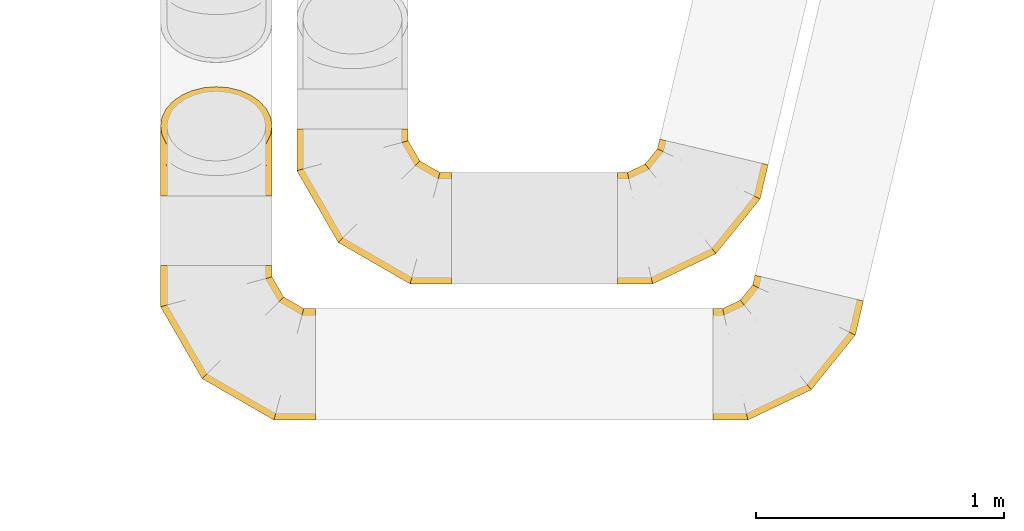
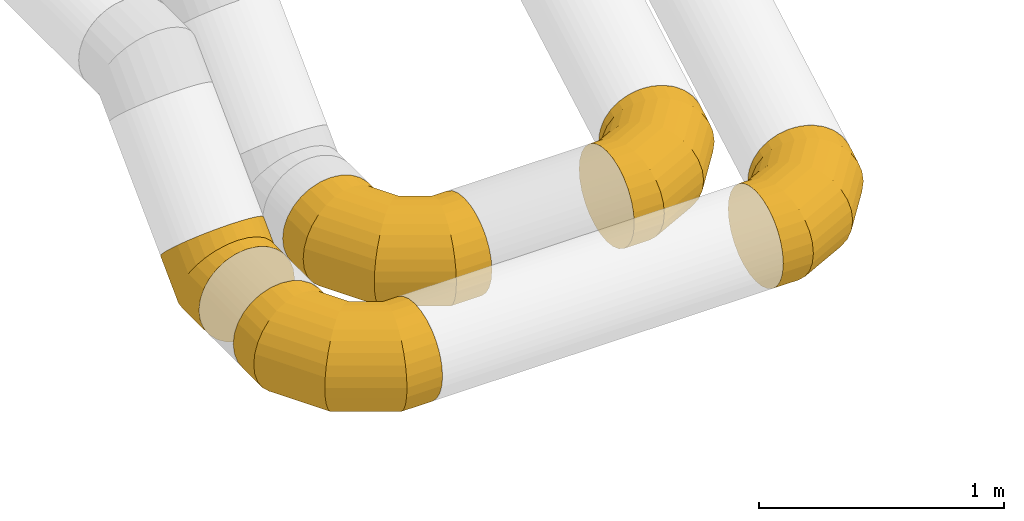
# One storey, part 14 of 97: 5 coverings.
"""IFC2X3 building model written with IfcOpenShell, lengths in millimetres."""

from ifc_helpers import new_model, entity, si_unit, converted_unit, derived_unit, direction, frame, origin, place, context, subcontext, project, spatial, faceted_brep, element, save


model = new_model("IFC2X3")

# Units and contexts
model_context = context("Model", 3, precision=0.01, world=origin(), true_north=direction((6.12303176911189e-17, 1.0)))
body_context = subcontext(model_context, "Body", "Model", "MODEL_VIEW")
ifc_project = project(units=[si_unit("LENGTHUNIT", "METRE", prefix="MILLI"), si_unit("AREAUNIT", "SQUARE_METRE"), si_unit("VOLUMEUNIT", "CUBIC_METRE"), converted_unit("PLANEANGLEUNIT", "DEGREE", entity("IfcRatioMeasure", 0.0174532925199433), si_unit("PLANEANGLEUNIT", "RADIAN"), dimensions=[0, 0, 0, 0, 0, 0, 0]), si_unit("MASSUNIT", "GRAM", prefix="KILO"), derived_unit("MASSDENSITYUNIT", [(si_unit("MASSUNIT", "GRAM", prefix="KILO"), 1), (si_unit("LENGTHUNIT", "METRE"), -3)]), derived_unit("MOMENTOFINERTIAUNIT", [(si_unit("LENGTHUNIT", "METRE"), 4)]), si_unit("TIMEUNIT", "SECOND"), si_unit("FREQUENCYUNIT", "HERTZ"), si_unit("THERMODYNAMICTEMPERATUREUNIT", "DEGREE_CELSIUS"), derived_unit("THERMALTRANSMITTANCEUNIT", [(si_unit("MASSUNIT", "GRAM", prefix="KILO"), 1), (si_unit("THERMODYNAMICTEMPERATUREUNIT", "KELVIN"), -1), (si_unit("TIMEUNIT", "SECOND"), -3)]), derived_unit("VOLUMETRICFLOWRATEUNIT", [(si_unit("LENGTHUNIT", "METRE"), 3), (si_unit("TIMEUNIT", "SECOND"), -1)]), derived_unit("MASSFLOWRATEUNIT", [(si_unit("MASSUNIT", "GRAM", prefix="KILO"), 1), (si_unit("TIMEUNIT", "SECOND"), -1)]), derived_unit("ROTATIONALFREQUENCYUNIT", [(si_unit("TIMEUNIT", "SECOND"), -1)]), si_unit("ELECTRICCURRENTUNIT", "AMPERE"), si_unit("ELECTRICVOLTAGEUNIT", "VOLT"), si_unit("POWERUNIT", "WATT"), si_unit("FORCEUNIT", "NEWTON", prefix="KILO"), si_unit("ILLUMINANCEUNIT", "LUX"), si_unit("LUMINOUSFLUXUNIT", "LUMEN"), si_unit("LUMINOUSINTENSITYUNIT", "CANDELA"), derived_unit("USERDEFINED", [(si_unit("MASSUNIT", "GRAM", prefix="KILO"), -1), (si_unit("LENGTHUNIT", "METRE"), -2), (si_unit("TIMEUNIT", "SECOND"), 3), (si_unit("LUMINOUSFLUXUNIT", "LUMEN"), 1)]), derived_unit("LINEARVELOCITYUNIT", [(si_unit("LENGTHUNIT", "METRE"), 1), (si_unit("TIMEUNIT", "SECOND"), -1)]), si_unit("PRESSUREUNIT", "PASCAL"), derived_unit("USERDEFINED", [(si_unit("LENGTHUNIT", "METRE"), -2), (si_unit("MASSUNIT", "GRAM", prefix="KILO"), 1), (si_unit("TIMEUNIT", "SECOND"), -2)]), derived_unit("LINEARFORCEUNIT", [(si_unit("MASSUNIT", "GRAM", prefix="KILO"), 1), (si_unit("LENGTHUNIT", "METRE"), 1), (si_unit("TIMEUNIT", "SECOND"), -2), (si_unit("LENGTHUNIT", "METRE"), -1)]), derived_unit("PLANARFORCEUNIT", [(si_unit("MASSUNIT", "GRAM", prefix="KILO"), 1), (si_unit("LENGTHUNIT", "METRE"), 1), (si_unit("TIMEUNIT", "SECOND"), -2), (si_unit("LENGTHUNIT", "METRE"), -2)])], contexts=[model_context])

# Site, building, storey
site_placement = place(None, origin())
site = spatial("IfcSite", under=ifc_project, at=site_placement, CompositionType="ELEMENT")
building_placement = place(site_placement, origin())
building = spatial("IfcBuilding", under=site, at=building_placement, CompositionType="ELEMENT")
storey_placement = place(building_placement, frame((0.0, 0.0, -4900.0)))
storey = spatial("IfcBuildingStorey", under=building, at=storey_placement, CompositionType="ELEMENT", Elevation=-4900.0)

# Coverings
covering_1_placement = place(storey_placement, frame((53084.14, 1571.63, 2723.4)))
element("IfcCovering", 1, at=covering_1_placement, inside=storey, PredefinedType="INSULATION", context=body_context, shape_type="Brep", body=[
    faceted_brep([(175.78, 584.96, 276.66), (191.97, 581.13, 324.22), (218.06, 574.95, 366.88), (252.72, 566.74, 402.51), (294.24, 556.91, 429.31), (340.51, 545.95, 445.95), (389.23, 534.41, 451.6), (437.95, 522.87, 445.95), (484.23, 511.91, 429.31), (525.74, 502.08, 402.51), (560.41, 493.87, 366.88), (586.49, 487.69, 324.22), (602.69, 483.85, 276.66), (608.18, 482.55, 226.6), (602.69, 483.85, 176.53), (586.49, 487.69, 128.97), (560.41, 493.87, 86.31), (525.74, 502.08, 50.68), (484.23, 511.91, 23.88), (437.95, 522.87, 7.24), (389.23, 534.41, 1.6), (340.51, 545.95, 7.24), (294.24, 556.91, 23.88), (252.72, 566.74, 50.68), (218.06, 574.95, 86.31), (191.97, 581.13, 128.97), (175.78, 584.96, 176.53), (170.29, 586.26, 226.6), (0.0, 50.68, 86.31), (0.0, 23.88, 128.97), (0.0, 7.24, 176.53), (0.0, 1.6, 226.6), (0.0, 7.24, 276.66), (0.0, 23.88, 324.22), (0.0, 50.68, 366.88), (0.0, 86.31, 402.51), (0.0, 128.97, 429.31), (0.0, 176.53, 445.95), (0.0, 226.6, 451.6), (0.0, 276.66, 445.95), (0.0, 324.22, 429.31), (0.0, 366.88, 402.51), (0.0, 402.51, 366.88), (0.0, 429.31, 324.22), (0.0, 445.95, 276.66), (0.0, 451.6, 226.6), (0.0, 445.95, 176.53), (0.0, 429.31, 128.97), (0.0, 402.51, 86.31), (0.0, 366.88, 50.68), (0.0, 324.22, 23.88), (0.0, 276.66, 7.24), (0.0, 226.6, 1.6), (0.0, 176.53, 7.24), (0.0, 128.97, 23.88), (0.0, 86.31, 50.68), (141.76, 1.6, 226.6), (140.48, 7.24, 276.66), (136.7, 23.88, 324.22), (130.62, 50.68, 366.88), (122.54, 86.31, 402.51), (112.87, 128.97, 429.31), (102.08, 176.53, 445.95), (90.73, 226.6, 451.6), (79.37, 276.66, 445.95), (68.58, 324.22, 429.31), (58.91, 366.88, 402.51), (50.83, 402.51, 366.88), (44.75, 429.31, 324.22), (40.97, 445.95, 276.66), (39.69, 451.6, 226.6), (40.97, 445.95, 176.53), (44.75, 429.31, 128.97), (50.83, 402.51, 86.31), (58.91, 366.88, 50.68), (68.58, 324.22, 23.88), (79.37, 276.66, 7.24), (90.73, 226.6, 1.6), (102.08, 176.53, 7.24), (112.87, 128.97, 23.88), (122.54, 86.31, 50.68), (130.62, 50.68, 86.31), (136.7, 23.88, 128.97), (140.48, 7.24, 176.53), (397.53, 123.91, 226.6), (393.94, 128.45, 276.66), (383.36, 141.83, 324.22), (366.31, 163.39, 366.88), (343.65, 192.05, 402.51), (316.51, 226.36, 429.31), (286.27, 264.61, 445.95), (254.42, 304.88, 451.6), (222.58, 345.15, 445.95), (192.33, 383.4, 429.31), (165.19, 417.71, 402.51), (142.53, 446.36, 366.88), (125.48, 467.92, 324.22), (114.9, 481.31, 276.66), (111.31, 485.84, 226.6), (114.9, 481.31, 176.53), (125.48, 467.92, 128.97), (142.53, 446.36, 86.31), (165.19, 417.71, 50.68), (192.33, 383.4, 23.88), (222.58, 345.15, 7.24), (254.42, 304.88, 1.6), (286.27, 264.61, 7.24), (316.51, 226.36, 23.88), (343.65, 192.05, 50.68), (366.31, 163.39, 86.31), (383.36, 141.83, 128.97), (393.94, 128.45, 176.53), (575.5, 344.61, 226.6), (570.31, 347.16, 276.66), (554.99, 354.66, 324.22), (530.3, 366.76, 366.88), (497.5, 382.83, 402.51), (458.22, 402.08, 429.31), (414.43, 423.54, 445.95), (368.32, 446.13, 451.6), (322.22, 468.71, 445.95), (278.43, 490.17, 429.31), (239.15, 509.42, 402.51), (206.34, 525.49, 366.88), (181.66, 537.59, 324.22), (166.34, 545.09, 276.66), (161.14, 547.64, 226.6), (166.34, 545.09, 176.53), (181.66, 537.59, 128.97), (206.34, 525.49, 86.31), (239.15, 509.42, 50.68), (278.43, 490.17, 23.88), (322.22, 468.71, 7.24), (368.32, 446.13, 1.6), (414.43, 423.54, 7.24), (458.22, 402.08, 23.88), (497.5, 382.83, 50.68), (530.3, 366.76, 86.31), (554.99, 354.66, 128.97), (570.31, 347.16, 176.53)], [[[0, 1, 2, 3, 4, 5, 6, 7, 8, 9, 10, 11, 12, 13, 14, 15, 16, 17, 18, 19, 20, 21, 22, 23, 24, 25, 26, 27]], [[28, 29, 30, 31, 32, 33, 34, 35, 36, 37, 38, 39, 40, 41, 42, 43, 44, 45, 46, 47, 48, 49, 50, 51, 52, 53, 54, 55]], [[31, 56, 57, 32]], [[32, 57, 58, 33]], [[33, 58, 59, 34]], [[59, 60, 35, 34]], [[35, 60, 61, 36]], [[36, 61, 62, 37]], [[37, 62, 63, 38]], [[63, 64, 39, 38]], [[65, 66, 41, 40]], [[64, 65, 40, 39]], [[66, 67, 42, 41]], [[67, 68, 43, 42]], [[69, 70, 45, 44]], [[68, 69, 44, 43]], [[70, 71, 46, 45]], [[72, 73, 48, 47]], [[71, 72, 47, 46]], [[73, 74, 49, 48]], [[74, 75, 50, 49]], [[76, 77, 52, 51]], [[75, 76, 51, 50]], [[53, 52, 77, 78]], [[78, 79, 54, 53]], [[80, 55, 54, 79]], [[80, 81, 28, 55]], [[29, 28, 81, 82]], [[82, 83, 30, 29]], [[56, 31, 30, 83]], [[57, 56, 84, 85]], [[57, 85, 86, 58]], [[59, 58, 86, 87]], [[87, 88, 60, 59]], [[61, 60, 88, 89]], [[62, 61, 89, 90]], [[63, 62, 90, 91]], [[91, 92, 64, 63]], [[93, 94, 66, 65]], [[92, 93, 65, 64]], [[94, 95, 67, 66]], [[95, 96, 68, 67]], [[97, 98, 70, 69]], [[96, 97, 69, 68]], [[98, 99, 71, 70]], [[100, 101, 73, 72]], [[99, 100, 72, 71]], [[101, 102, 74, 73]], [[102, 103, 75, 74]], [[104, 105, 77, 76]], [[103, 104, 76, 75]], [[78, 77, 105, 106]], [[106, 107, 79, 78]], [[108, 80, 79, 107]], [[108, 109, 81, 80]], [[82, 81, 109, 110]], [[110, 111, 83, 82]], [[84, 56, 83, 111]], [[85, 84, 112, 113]], [[85, 113, 114, 86]], [[87, 86, 114, 115]], [[115, 116, 88, 87]], [[89, 88, 116, 117]], [[90, 89, 117, 118]], [[91, 90, 118, 119]], [[119, 120, 92, 91]], [[121, 122, 94, 93]], [[120, 121, 93, 92]], [[122, 123, 95, 94]], [[123, 124, 96, 95]], [[125, 126, 98, 97]], [[124, 125, 97, 96]], [[126, 127, 99, 98]], [[128, 129, 101, 100]], [[127, 128, 100, 99]], [[129, 130, 102, 101]], [[130, 131, 103, 102]], [[132, 133, 105, 104]], [[131, 132, 104, 103]], [[106, 105, 133, 134]], [[134, 135, 107, 106]], [[136, 108, 107, 135]], [[136, 137, 109, 108]], [[110, 109, 137, 138]], [[138, 139, 111, 110]], [[112, 84, 111, 139]], [[113, 112, 13, 12]], [[114, 113, 12, 11]], [[115, 114, 11, 10]], [[10, 9, 116, 115]], [[117, 116, 9, 8]], [[118, 117, 8, 7]], [[119, 118, 7, 6]], [[120, 119, 6, 5]], [[5, 4, 121, 120]], [[3, 122, 121, 4]], [[3, 2, 123, 122]], [[124, 123, 2, 1]], [[125, 124, 1, 0]], [[126, 125, 0, 27]], [[126, 27, 26, 127]], [[26, 25, 128, 127]], [[24, 129, 128, 25]], [[24, 23, 130, 129]], [[130, 23, 22, 131]], [[131, 22, 21, 132]], [[132, 21, 20, 133]], [[133, 20, 19, 134]], [[134, 19, 18, 135]], [[135, 18, 17, 136]], [[17, 16, 137, 136]], [[137, 16, 15, 138]], [[138, 15, 14, 139]], [[139, 14, 13, 112]]]),
])
covering_2_placement = place(storey_placement, frame((51787.5, 1571.63, 2723.4)))
element("IfcCovering", 2, at=covering_2_placement, inside=storey, PredefinedType="INSULATION", context=body_context, shape_type="Brep", body=[
    faceted_brep([(626.6, 226.6, 451.6), (626.6, 176.53, 445.95), (626.6, 128.97, 429.31), (626.6, 86.31, 402.51), (626.6, 50.68, 366.88), (626.6, 23.88, 324.22), (626.6, 7.24, 276.66), (626.6, 1.6, 226.6), (626.6, 7.24, 176.53), (626.6, 23.88, 128.97), (626.6, 50.68, 86.31), (626.6, 86.31, 50.68), (626.6, 128.97, 23.88), (626.6, 176.53, 7.24), (626.6, 226.6, 1.6), (626.6, 276.66, 7.24), (626.6, 324.22, 23.88), (626.6, 366.88, 50.68), (626.6, 402.51, 86.31), (626.6, 429.31, 128.97), (626.6, 445.95, 176.53), (626.6, 451.6, 226.6), (626.6, 445.95, 276.66), (626.6, 429.31, 324.22), (626.6, 402.51, 366.88), (626.6, 366.88, 402.51), (626.6, 324.22, 429.31), (626.6, 276.66, 445.95), (50.68, 626.6, 86.31), (23.88, 626.6, 128.97), (7.24, 626.6, 176.53), (1.6, 626.6, 226.6), (7.24, 626.6, 276.66), (23.88, 626.6, 324.22), (50.68, 626.6, 366.88), (86.31, 626.6, 402.51), (128.97, 626.6, 429.31), (176.53, 626.6, 445.95), (226.6, 626.6, 451.6), (276.66, 626.6, 445.95), (324.22, 626.6, 429.31), (366.88, 626.6, 402.51), (402.51, 626.6, 366.88), (429.31, 626.6, 324.22), (445.95, 626.6, 276.66), (451.6, 626.6, 226.6), (445.95, 626.6, 176.53), (429.31, 626.6, 128.97), (402.51, 626.6, 86.31), (366.88, 626.6, 50.68), (324.22, 626.6, 23.88), (276.66, 626.6, 7.24), (226.6, 626.6, 1.6), (176.53, 626.6, 7.24), (128.97, 626.6, 23.88), (86.31, 626.6, 50.68), (1.6, 459.13, 226.6), (7.24, 460.64, 276.66), (23.88, 465.1, 324.22), (50.68, 472.28, 366.88), (86.31, 481.83, 402.51), (128.97, 493.26, 429.31), (176.53, 506.0, 445.95), (226.6, 519.42, 451.6), (276.66, 532.83, 445.95), (324.22, 545.57, 429.31), (366.88, 557.0, 402.51), (402.51, 566.55, 366.88), (429.31, 573.73, 324.22), (445.95, 578.19, 276.66), (451.6, 579.7, 226.6), (445.95, 578.19, 176.53), (429.31, 573.73, 128.97), (402.51, 566.55, 86.31), (366.88, 557.0, 50.68), (324.22, 545.57, 23.88), (276.66, 532.83, 7.24), (226.6, 519.42, 1.6), (176.53, 506.0, 7.24), (128.97, 493.26, 23.88), (86.31, 481.83, 50.68), (50.68, 472.28, 86.31), (23.88, 465.1, 128.97), (7.24, 460.64, 176.53), (169.06, 169.06, 226.6), (173.19, 173.19, 276.66), (185.38, 185.38, 324.22), (205.0, 205.0, 366.88), (231.08, 231.08, 402.51), (262.31, 262.31, 429.31), (297.12, 297.12, 445.95), (333.77, 333.77, 451.6), (370.43, 370.43, 445.95), (405.24, 405.24, 429.31), (436.47, 436.47, 402.51), (462.55, 462.55, 366.88), (482.17, 482.17, 324.22), (494.36, 494.36, 276.66), (498.49, 498.49, 226.6), (494.36, 494.36, 176.53), (482.17, 482.17, 128.97), (462.55, 462.55, 86.31), (436.47, 436.47, 50.68), (405.24, 405.24, 23.88), (370.43, 370.43, 7.24), (333.77, 333.77, 1.6), (297.12, 297.12, 7.24), (262.31, 262.31, 23.88), (231.08, 231.08, 50.68), (205.0, 205.0, 86.31), (185.38, 185.38, 128.97), (173.19, 173.19, 176.53), (459.13, 1.6, 226.6), (460.64, 7.24, 276.66), (465.1, 23.88, 324.22), (472.28, 50.68, 366.88), (481.83, 86.31, 402.51), (493.26, 128.97, 429.31), (506.0, 176.53, 445.95), (519.42, 226.6, 451.6), (532.83, 276.66, 445.95), (545.57, 324.22, 429.31), (557.0, 366.88, 402.51), (566.55, 402.51, 366.88), (573.73, 429.31, 324.22), (578.19, 445.95, 276.66), (579.7, 451.6, 226.6), (578.19, 445.95, 176.53), (573.73, 429.31, 128.97), (566.55, 402.51, 86.31), (557.0, 366.88, 50.68), (545.57, 324.22, 23.88), (532.83, 276.66, 7.24), (519.42, 226.6, 1.6), (506.0, 176.53, 7.24), (493.26, 128.97, 23.88), (481.83, 86.31, 50.68), (472.28, 50.68, 86.31), (465.1, 23.88, 128.97), (460.64, 7.24, 176.53)], [[[0, 1, 2, 3, 4, 5, 6, 7, 8, 9, 10, 11, 12, 13, 14, 15, 16, 17, 18, 19, 20, 21, 22, 23, 24, 25, 26, 27]], [[28, 29, 30, 31, 32, 33, 34, 35, 36, 37, 38, 39, 40, 41, 42, 43, 44, 45, 46, 47, 48, 49, 50, 51, 52, 53, 54, 55]], [[31, 56, 57, 32]], [[32, 57, 58, 33]], [[33, 58, 59, 34]], [[59, 60, 35, 34]], [[35, 60, 61, 36]], [[36, 61, 62, 37]], [[37, 62, 63, 38]], [[63, 64, 39, 38]], [[65, 66, 41, 40]], [[64, 65, 40, 39]], [[66, 67, 42, 41]], [[67, 68, 43, 42]], [[69, 70, 45, 44]], [[68, 69, 44, 43]], [[70, 71, 46, 45]], [[72, 73, 48, 47]], [[71, 72, 47, 46]], [[73, 74, 49, 48]], [[74, 75, 50, 49]], [[76, 77, 52, 51]], [[75, 76, 51, 50]], [[53, 52, 77, 78]], [[78, 79, 54, 53]], [[80, 55, 54, 79]], [[80, 81, 28, 55]], [[29, 28, 81, 82]], [[82, 83, 30, 29]], [[56, 31, 30, 83]], [[57, 56, 84, 85]], [[57, 85, 86, 58]], [[59, 58, 86, 87]], [[87, 88, 60, 59]], [[61, 60, 88, 89]], [[62, 61, 89, 90]], [[63, 62, 90, 91]], [[91, 92, 64, 63]], [[93, 94, 66, 65]], [[92, 93, 65, 64]], [[94, 95, 67, 66]], [[95, 96, 68, 67]], [[97, 98, 70, 69]], [[96, 97, 69, 68]], [[98, 99, 71, 70]], [[100, 101, 73, 72]], [[99, 100, 72, 71]], [[101, 102, 74, 73]], [[102, 103, 75, 74]], [[104, 105, 77, 76]], [[103, 104, 76, 75]], [[78, 77, 105, 106]], [[106, 107, 79, 78]], [[108, 80, 79, 107]], [[108, 109, 81, 80]], [[82, 81, 109, 110]], [[110, 111, 83, 82]], [[84, 56, 83, 111]], [[85, 84, 112, 113]], [[85, 113, 114, 86]], [[87, 86, 114, 115]], [[115, 116, 88, 87]], [[89, 88, 116, 117]], [[90, 89, 117, 118]], [[91, 90, 118, 119]], [[119, 120, 92, 91]], [[121, 122, 94, 93]], [[120, 121, 93, 92]], [[122, 123, 95, 94]], [[123, 124, 96, 95]], [[125, 126, 98, 97]], [[124, 125, 97, 96]], [[126, 127, 99, 98]], [[128, 129, 101, 100]], [[127, 128, 100, 99]], [[129, 130, 102, 101]], [[130, 131, 103, 102]], [[132, 133, 105, 104]], [[131, 132, 104, 103]], [[106, 105, 133, 134]], [[134, 135, 107, 106]], [[136, 108, 107, 135]], [[136, 137, 109, 108]], [[110, 109, 137, 138]], [[138, 139, 111, 110]], [[112, 84, 111, 139]], [[113, 112, 7, 6]], [[5, 4, 115, 114]], [[114, 113, 6, 5]], [[4, 3, 116, 115]], [[117, 116, 3, 2]], [[118, 117, 2, 1]], [[119, 118, 1, 0]], [[120, 119, 0, 27]], [[26, 25, 122, 121]], [[121, 120, 27, 26]], [[25, 24, 123, 122]], [[124, 123, 24, 23]], [[125, 124, 23, 22]], [[126, 125, 22, 21]], [[21, 20, 127, 126]], [[20, 19, 128, 127]], [[128, 19, 18, 129]], [[18, 17, 130, 129]], [[130, 17, 16, 131]], [[131, 16, 15, 132]], [[132, 15, 14, 133]], [[133, 14, 13, 134]], [[134, 13, 12, 135]], [[135, 12, 11, 136]], [[11, 10, 137, 136]], [[137, 10, 9, 138]], [[138, 9, 8, 139]], [[139, 8, 7, 112]]]),
])
covering_3_placement = place(storey_placement, frame((51237.56, 1927.86, 2723.4)))
element("IfcCovering", 3, at=covering_3_placement, inside=storey, PredefinedType="INSULATION", context=body_context, shape_type="Brep", body=[
    faceted_brep([(176.53, 0.0, 445.95), (128.97, 0.0, 429.31), (86.31, 0.0, 402.51), (50.68, 0.0, 366.88), (23.88, 0.0, 324.22), (7.24, 0.0, 276.66), (1.6, 0.0, 226.6), (7.24, 0.0, 176.53), (23.88, 0.0, 128.97), (50.68, 0.0, 86.31), (86.31, 0.0, 50.68), (128.97, 0.0, 23.88), (176.53, 0.0, 7.24), (226.6, 0.0, 1.6), (276.66, 0.0, 7.24), (324.22, 0.0, 23.88), (366.88, 0.0, 50.68), (402.51, 0.0, 86.31), (429.31, 0.0, 128.97), (445.95, 0.0, 176.53), (451.6, 0.0, 226.6), (445.95, 0.0, 276.66), (429.31, 0.0, 324.22), (402.51, 0.0, 366.88), (366.88, 0.0, 402.51), (324.22, 0.0, 429.31), (276.66, 0.0, 445.95), (226.6, 0.0, 451.6), (366.88, 407.23, 219.36), (324.22, 426.19, 200.41), (276.66, 437.95, 188.64), (226.6, 441.94, 184.65), (176.53, 437.95, 188.64), (128.97, 426.19, 200.41), (86.31, 407.23, 219.36), (50.68, 382.04, 244.56), (23.88, 351.87, 274.72), (7.24, 318.25, 308.35), (1.6, 282.84, 343.75), (7.24, 247.44, 379.16), (23.88, 213.81, 412.78), (50.68, 183.65, 442.95), (86.31, 158.45, 468.14), (128.97, 139.5, 487.1), (176.53, 127.73, 498.86), (226.6, 123.74, 502.85), (276.66, 127.73, 498.86), (324.22, 139.5, 487.1), (366.88, 158.45, 468.14), (402.51, 183.65, 442.95), (429.31, 213.81, 412.78), (445.95, 247.44, 379.16), (451.6, 282.84, 343.75), (445.95, 318.25, 308.35), (429.31, 351.87, 274.72), (402.51, 382.04, 244.56), (226.6, 258.88, 1.6), (176.53, 256.55, 7.24), (128.97, 249.65, 23.88), (86.31, 238.55, 50.68), (50.68, 223.79, 86.31), (23.88, 206.12, 128.97), (7.24, 186.42, 176.53), (1.6, 165.69, 226.6), (7.24, 144.95, 276.66), (23.88, 125.25, 324.22), (50.68, 107.58, 366.88), (86.31, 92.82, 402.51), (128.97, 81.72, 429.31), (176.53, 74.82, 445.95), (226.6, 72.49, 451.6), (276.66, 74.82, 445.95), (324.22, 81.72, 429.31), (366.88, 92.82, 402.51), (402.51, 107.58, 366.88), (429.31, 125.25, 324.22), (445.95, 144.95, 276.66), (451.6, 165.69, 226.6), (445.95, 186.42, 176.53), (429.31, 206.12, 128.97), (402.51, 223.79, 86.31), (366.88, 238.55, 50.68), (324.22, 249.65, 23.88), (276.66, 256.55, 7.24)], [[[0, 1, 2, 3, 4, 5, 6, 7, 8, 9, 10, 11, 12, 13, 14, 15, 16, 17, 18, 19, 20, 21, 22, 23, 24, 25, 26, 27]], [[28, 29, 30, 31, 32, 33, 34, 35, 36, 37, 38, 39, 40, 41, 42, 43, 44, 45, 46, 47, 48, 49, 50, 51, 52, 53, 54, 55]], [[31, 56, 57, 32]], [[32, 57, 58, 33]], [[33, 58, 59, 34]], [[59, 60, 35, 34]], [[35, 60, 61, 36]], [[36, 61, 62, 37]], [[37, 62, 63, 38]], [[63, 64, 39, 38]], [[65, 66, 41, 40]], [[64, 65, 40, 39]], [[66, 67, 42, 41]], [[67, 68, 43, 42]], [[69, 70, 45, 44]], [[68, 69, 44, 43]], [[70, 71, 46, 45]], [[72, 73, 48, 47]], [[71, 72, 47, 46]], [[73, 74, 49, 48]], [[74, 75, 50, 49]], [[76, 77, 52, 51]], [[75, 76, 51, 50]], [[53, 52, 77, 78]], [[78, 79, 54, 53]], [[80, 55, 54, 79]], [[80, 81, 28, 55]], [[29, 28, 81, 82]], [[82, 83, 30, 29]], [[56, 31, 30, 83]], [[13, 12, 57, 56]], [[11, 10, 59, 58]], [[12, 11, 58, 57]], [[10, 9, 60, 59]], [[61, 60, 9, 8]], [[62, 61, 8, 7]], [[63, 62, 7, 6]], [[64, 63, 6, 5]], [[65, 64, 5, 4]], [[66, 65, 4, 3]], [[3, 2, 67, 66]], [[68, 67, 2, 1]], [[69, 68, 1, 0]], [[70, 69, 0, 27]], [[70, 27, 26, 71]], [[71, 26, 25, 72]], [[72, 25, 24, 73]], [[24, 23, 74, 73]], [[74, 23, 22, 75]], [[75, 22, 21, 76]], [[76, 21, 20, 77]], [[77, 20, 19, 78]], [[78, 19, 18, 79]], [[79, 18, 17, 80]], [[17, 16, 81, 80]], [[81, 16, 15, 82]], [[82, 15, 14, 83]], [[83, 14, 13, 56]]]),
])
covering_4_placement = place(storey_placement, frame((51237.56, 1022.13, 2723.4)))
element("IfcCovering", 4, at=covering_4_placement, inside=storey, PredefinedType="INSULATION", context=body_context, shape_type="Brep", body=[
    faceted_brep([(626.6, 226.6, 451.6), (626.6, 176.53, 445.95), (626.6, 128.97, 429.31), (626.6, 86.31, 402.51), (626.6, 50.68, 366.88), (626.6, 23.88, 324.22), (626.6, 7.24, 276.66), (626.6, 1.6, 226.6), (626.6, 7.24, 176.53), (626.6, 23.88, 128.97), (626.6, 50.68, 86.31), (626.6, 86.31, 50.68), (626.6, 128.97, 23.88), (626.6, 176.53, 7.24), (626.6, 226.6, 1.6), (626.6, 276.66, 7.24), (626.6, 324.22, 23.88), (626.6, 366.88, 50.68), (626.6, 402.51, 86.31), (626.6, 429.31, 128.97), (626.6, 445.95, 176.53), (626.6, 451.6, 226.6), (626.6, 445.95, 276.66), (626.6, 429.31, 324.22), (626.6, 402.51, 366.88), (626.6, 366.88, 402.51), (626.6, 324.22, 429.31), (626.6, 276.66, 445.95), (50.68, 626.6, 86.31), (23.88, 626.6, 128.97), (7.24, 626.6, 176.53), (1.6, 626.6, 226.6), (7.24, 626.6, 276.66), (23.88, 626.6, 324.22), (50.68, 626.6, 366.88), (86.31, 626.6, 402.51), (128.97, 626.6, 429.31), (176.53, 626.6, 445.95), (226.6, 626.6, 451.6), (276.66, 626.6, 445.95), (324.22, 626.6, 429.31), (366.88, 626.6, 402.51), (402.51, 626.6, 366.88), (429.31, 626.6, 324.22), (445.95, 626.6, 276.66), (451.6, 626.6, 226.6), (445.95, 626.6, 176.53), (429.31, 626.6, 128.97), (402.51, 626.6, 86.31), (366.88, 626.6, 50.68), (324.22, 626.6, 23.88), (276.66, 626.6, 7.24), (226.6, 626.6, 1.6), (176.53, 626.6, 7.24), (128.97, 626.6, 23.88), (86.31, 626.6, 50.68), (1.6, 459.13, 226.6), (7.24, 460.64, 276.66), (23.88, 465.1, 324.22), (50.68, 472.28, 366.88), (86.31, 481.83, 402.51), (128.97, 493.26, 429.31), (176.53, 506.0, 445.95), (226.6, 519.42, 451.6), (276.66, 532.83, 445.95), (324.22, 545.57, 429.31), (366.88, 557.0, 402.51), (402.51, 566.55, 366.88), (429.31, 573.73, 324.22), (445.95, 578.19, 276.66), (451.6, 579.7, 226.6), (445.95, 578.19, 176.53), (429.31, 573.73, 128.97), (402.51, 566.55, 86.31), (366.88, 557.0, 50.68), (324.22, 545.57, 23.88), (276.66, 532.83, 7.24), (226.6, 519.42, 1.6), (176.53, 506.0, 7.24), (128.97, 493.26, 23.88), (86.31, 481.83, 50.68), (50.68, 472.28, 86.31), (23.88, 465.1, 128.97), (7.24, 460.64, 176.53), (169.06, 169.06, 226.6), (173.19, 173.19, 276.66), (185.38, 185.38, 324.22), (205.0, 205.0, 366.88), (231.08, 231.08, 402.51), (262.31, 262.31, 429.31), (297.12, 297.12, 445.95), (333.77, 333.77, 451.6), (370.43, 370.43, 445.95), (405.24, 405.24, 429.31), (436.47, 436.47, 402.51), (462.55, 462.55, 366.88), (482.17, 482.17, 324.22), (494.36, 494.36, 276.66), (498.49, 498.49, 226.6), (494.36, 494.36, 176.53), (482.17, 482.17, 128.97), (462.55, 462.55, 86.31), (436.47, 436.47, 50.68), (405.24, 405.24, 23.88), (370.43, 370.43, 7.24), (333.77, 333.77, 1.6), (297.12, 297.12, 7.24), (262.31, 262.31, 23.88), (231.08, 231.08, 50.68), (205.0, 205.0, 86.31), (185.38, 185.38, 128.97), (173.19, 173.19, 176.53), (459.13, 1.6, 226.6), (460.64, 7.24, 276.66), (465.1, 23.88, 324.22), (472.28, 50.68, 366.88), (481.83, 86.31, 402.51), (493.26, 128.97, 429.31), (506.0, 176.53, 445.95), (519.42, 226.6, 451.6), (532.83, 276.66, 445.95), (545.57, 324.22, 429.31), (557.0, 366.88, 402.51), (566.55, 402.51, 366.88), (573.73, 429.31, 324.22), (578.19, 445.95, 276.66), (579.7, 451.6, 226.6), (578.19, 445.95, 176.53), (573.73, 429.31, 128.97), (566.55, 402.51, 86.31), (557.0, 366.88, 50.68), (545.57, 324.22, 23.88), (532.83, 276.66, 7.24), (519.42, 226.6, 1.6), (506.0, 176.53, 7.24), (493.26, 128.97, 23.88), (481.83, 86.31, 50.68), (472.28, 50.68, 86.31), (465.1, 23.88, 128.97), (460.64, 7.24, 176.53)], [[[0, 1, 2, 3, 4, 5, 6, 7, 8, 9, 10, 11, 12, 13, 14, 15, 16, 17, 18, 19, 20, 21, 22, 23, 24, 25, 26, 27]], [[28, 29, 30, 31, 32, 33, 34, 35, 36, 37, 38, 39, 40, 41, 42, 43, 44, 45, 46, 47, 48, 49, 50, 51, 52, 53, 54, 55]], [[31, 56, 57, 32]], [[32, 57, 58, 33]], [[33, 58, 59, 34]], [[59, 60, 35, 34]], [[35, 60, 61, 36]], [[36, 61, 62, 37]], [[37, 62, 63, 38]], [[63, 64, 39, 38]], [[65, 66, 41, 40]], [[64, 65, 40, 39]], [[66, 67, 42, 41]], [[67, 68, 43, 42]], [[69, 70, 45, 44]], [[68, 69, 44, 43]], [[70, 71, 46, 45]], [[72, 73, 48, 47]], [[71, 72, 47, 46]], [[73, 74, 49, 48]], [[74, 75, 50, 49]], [[76, 77, 52, 51]], [[75, 76, 51, 50]], [[53, 52, 77, 78]], [[78, 79, 54, 53]], [[80, 55, 54, 79]], [[80, 81, 28, 55]], [[29, 28, 81, 82]], [[82, 83, 30, 29]], [[56, 31, 30, 83]], [[57, 56, 84, 85]], [[57, 85, 86, 58]], [[59, 58, 86, 87]], [[87, 88, 60, 59]], [[61, 60, 88, 89]], [[62, 61, 89, 90]], [[63, 62, 90, 91]], [[91, 92, 64, 63]], [[93, 94, 66, 65]], [[92, 93, 65, 64]], [[94, 95, 67, 66]], [[95, 96, 68, 67]], [[97, 98, 70, 69]], [[96, 97, 69, 68]], [[98, 99, 71, 70]], [[100, 101, 73, 72]], [[99, 100, 72, 71]], [[101, 102, 74, 73]], [[102, 103, 75, 74]], [[104, 105, 77, 76]], [[103, 104, 76, 75]], [[78, 77, 105, 106]], [[106, 107, 79, 78]], [[108, 80, 79, 107]], [[108, 109, 81, 80]], [[82, 81, 109, 110]], [[110, 111, 83, 82]], [[84, 56, 83, 111]], [[85, 84, 112, 113]], [[85, 113, 114, 86]], [[87, 86, 114, 115]], [[115, 116, 88, 87]], [[89, 88, 116, 117]], [[90, 89, 117, 118]], [[91, 90, 118, 119]], [[119, 120, 92, 91]], [[121, 122, 94, 93]], [[120, 121, 93, 92]], [[122, 123, 95, 94]], [[123, 124, 96, 95]], [[125, 126, 98, 97]], [[124, 125, 97, 96]], [[126, 127, 99, 98]], [[128, 129, 101, 100]], [[127, 128, 100, 99]], [[129, 130, 102, 101]], [[130, 131, 103, 102]], [[132, 133, 105, 104]], [[131, 132, 104, 103]], [[106, 105, 133, 134]], [[134, 135, 107, 106]], [[136, 108, 107, 135]], [[136, 137, 109, 108]], [[110, 109, 137, 138]], [[138, 139, 111, 110]], [[112, 84, 111, 139]], [[113, 112, 7, 6]], [[5, 4, 115, 114]], [[114, 113, 6, 5]], [[4, 3, 116, 115]], [[117, 116, 3, 2]], [[118, 117, 2, 1]], [[119, 118, 1, 0]], [[120, 119, 0, 27]], [[26, 25, 122, 121]], [[121, 120, 27, 26]], [[25, 24, 123, 122]], [[124, 123, 24, 23]], [[125, 124, 23, 22]], [[126, 125, 22, 21]], [[21, 20, 127, 126]], [[20, 19, 128, 127]], [[128, 19, 18, 129]], [[18, 17, 130, 129]], [[130, 17, 16, 131]], [[131, 16, 15, 132]], [[132, 15, 14, 133]], [[133, 14, 13, 134]], [[134, 13, 12, 135]], [[135, 12, 11, 136]], [[11, 10, 137, 136]], [[137, 10, 9, 138]], [[138, 9, 8, 139]], [[139, 8, 7, 112]]]),
])
covering_5_placement = place(storey_placement, frame((53468.75, 1022.13, 2723.4)))
element("IfcCovering", 5, at=covering_5_placement, inside=storey, PredefinedType="INSULATION", context=body_context, shape_type="Brep", body=[
    faceted_brep([(294.24, 556.91, 429.31), (340.51, 545.95, 445.95), (389.23, 534.41, 451.6), (437.95, 522.87, 445.95), (484.23, 511.91, 429.31), (525.74, 502.08, 402.51), (560.41, 493.87, 366.88), (586.49, 487.69, 324.22), (602.69, 483.85, 276.66), (608.18, 482.55, 226.6), (602.69, 483.85, 176.53), (586.49, 487.69, 128.97), (560.41, 493.87, 86.31), (525.74, 502.08, 50.68), (484.23, 511.91, 23.88), (437.95, 522.87, 7.24), (389.23, 534.41, 1.6), (340.51, 545.95, 7.24), (294.24, 556.91, 23.88), (252.72, 566.74, 50.68), (218.06, 574.95, 86.31), (191.97, 581.13, 128.97), (175.78, 584.96, 176.53), (170.29, 586.26, 226.6), (175.78, 584.96, 276.66), (191.97, 581.13, 324.22), (218.06, 574.95, 366.88), (252.72, 566.74, 402.51), (0.0, 50.68, 86.31), (0.0, 23.88, 128.97), (0.0, 7.24, 176.53), (0.0, 1.6, 226.6), (0.0, 7.24, 276.66), (0.0, 23.88, 324.22), (0.0, 50.68, 366.88), (0.0, 86.31, 402.51), (0.0, 128.97, 429.31), (0.0, 176.53, 445.95), (0.0, 226.6, 451.6), (0.0, 276.66, 445.95), (0.0, 324.22, 429.31), (0.0, 366.88, 402.51), (0.0, 402.51, 366.88), (0.0, 429.31, 324.22), (0.0, 445.95, 276.66), (0.0, 451.6, 226.6), (0.0, 445.95, 176.53), (0.0, 429.31, 128.97), (0.0, 402.51, 86.31), (0.0, 366.88, 50.68), (0.0, 324.22, 23.88), (0.0, 276.66, 7.24), (0.0, 226.6, 1.6), (0.0, 176.53, 7.24), (0.0, 128.97, 23.88), (0.0, 86.31, 50.68), (141.76, 1.6, 226.6), (140.48, 7.24, 276.66), (136.7, 23.88, 324.22), (130.62, 50.68, 366.88), (122.54, 86.31, 402.51), (112.87, 128.97, 429.31), (102.08, 176.53, 445.95), (90.73, 226.6, 451.6), (79.37, 276.66, 445.95), (68.58, 324.22, 429.31), (58.91, 366.88, 402.51), (50.83, 402.51, 366.88), (44.75, 429.31, 324.22), (40.97, 445.95, 276.66), (39.69, 451.6, 226.6), (40.97, 445.95, 176.53), (44.75, 429.31, 128.97), (50.83, 402.51, 86.31), (58.91, 366.88, 50.68), (68.58, 324.22, 23.88), (79.37, 276.66, 7.24), (90.73, 226.6, 1.6), (102.08, 176.53, 7.24), (112.87, 128.97, 23.88), (122.54, 86.31, 50.68), (130.62, 50.68, 86.31), (136.7, 23.88, 128.97), (140.48, 7.24, 176.53), (397.53, 123.91, 226.6), (393.94, 128.45, 276.66), (383.36, 141.83, 324.22), (366.31, 163.39, 366.88), (343.65, 192.05, 402.51), (316.51, 226.36, 429.31), (286.27, 264.61, 445.95), (254.42, 304.88, 451.6), (222.58, 345.15, 445.95), (192.33, 383.4, 429.31), (165.19, 417.71, 402.51), (142.53, 446.36, 366.88), (125.48, 467.92, 324.22), (114.9, 481.31, 276.66), (111.31, 485.84, 226.6), (114.9, 481.31, 176.53), (125.48, 467.92, 128.97), (142.53, 446.36, 86.31), (165.19, 417.71, 50.68), (192.33, 383.4, 23.88), (222.58, 345.15, 7.24), (254.42, 304.88, 1.6), (286.27, 264.61, 7.24), (316.51, 226.36, 23.88), (343.65, 192.05, 50.68), (366.31, 163.39, 86.31), (383.36, 141.83, 128.97), (393.94, 128.45, 176.53), (575.5, 344.61, 226.6), (570.31, 347.16, 276.66), (554.99, 354.66, 324.22), (530.3, 366.76, 366.88), (497.5, 382.83, 402.51), (458.22, 402.08, 429.31), (414.43, 423.54, 445.95), (368.32, 446.13, 451.6), (322.22, 468.71, 445.95), (278.43, 490.17, 429.31), (239.15, 509.42, 402.51), (206.34, 525.49, 366.88), (181.66, 537.59, 324.22), (166.34, 545.09, 276.66), (161.14, 547.64, 226.6), (166.34, 545.09, 176.53), (181.66, 537.59, 128.97), (206.34, 525.49, 86.31), (239.15, 509.42, 50.68), (278.43, 490.17, 23.88), (322.22, 468.71, 7.24), (368.32, 446.13, 1.6), (414.43, 423.54, 7.24), (458.22, 402.08, 23.88), (497.5, 382.83, 50.68), (530.3, 366.76, 86.31), (554.99, 354.66, 128.97), (570.31, 347.16, 176.53)], [[[0, 1, 2, 3, 4, 5, 6, 7, 8, 9, 10, 11, 12, 13, 14, 15, 16, 17, 18, 19, 20, 21, 22, 23, 24, 25, 26, 27]], [[28, 29, 30, 31, 32, 33, 34, 35, 36, 37, 38, 39, 40, 41, 42, 43, 44, 45, 46, 47, 48, 49, 50, 51, 52, 53, 54, 55]], [[31, 56, 57, 32]], [[32, 57, 58, 33]], [[33, 58, 59, 34]], [[59, 60, 35, 34]], [[35, 60, 61, 36]], [[36, 61, 62, 37]], [[37, 62, 63, 38]], [[63, 64, 39, 38]], [[65, 66, 41, 40]], [[64, 65, 40, 39]], [[66, 67, 42, 41]], [[67, 68, 43, 42]], [[69, 70, 45, 44]], [[68, 69, 44, 43]], [[70, 71, 46, 45]], [[72, 73, 48, 47]], [[71, 72, 47, 46]], [[73, 74, 49, 48]], [[74, 75, 50, 49]], [[76, 77, 52, 51]], [[75, 76, 51, 50]], [[53, 52, 77, 78]], [[78, 79, 54, 53]], [[80, 55, 54, 79]], [[80, 81, 28, 55]], [[29, 28, 81, 82]], [[82, 83, 30, 29]], [[56, 31, 30, 83]], [[57, 56, 84, 85]], [[57, 85, 86, 58]], [[59, 58, 86, 87]], [[87, 88, 60, 59]], [[61, 60, 88, 89]], [[62, 61, 89, 90]], [[63, 62, 90, 91]], [[91, 92, 64, 63]], [[93, 94, 66, 65]], [[92, 93, 65, 64]], [[94, 95, 67, 66]], [[95, 96, 68, 67]], [[97, 98, 70, 69]], [[96, 97, 69, 68]], [[98, 99, 71, 70]], [[100, 101, 73, 72]], [[99, 100, 72, 71]], [[101, 102, 74, 73]], [[102, 103, 75, 74]], [[104, 105, 77, 76]], [[103, 104, 76, 75]], [[78, 77, 105, 106]], [[106, 107, 79, 78]], [[108, 80, 79, 107]], [[108, 109, 81, 80]], [[82, 81, 109, 110]], [[110, 111, 83, 82]], [[84, 56, 83, 111]], [[85, 84, 112, 113]], [[85, 113, 114, 86]], [[87, 86, 114, 115]], [[115, 116, 88, 87]], [[89, 88, 116, 117]], [[90, 89, 117, 118]], [[91, 90, 118, 119]], [[119, 120, 92, 91]], [[121, 122, 94, 93]], [[120, 121, 93, 92]], [[122, 123, 95, 94]], [[123, 124, 96, 95]], [[125, 126, 98, 97]], [[124, 125, 97, 96]], [[126, 127, 99, 98]], [[128, 129, 101, 100]], [[127, 128, 100, 99]], [[129, 130, 102, 101]], [[130, 131, 103, 102]], [[132, 133, 105, 104]], [[131, 132, 104, 103]], [[106, 105, 133, 134]], [[134, 135, 107, 106]], [[136, 108, 107, 135]], [[136, 137, 109, 108]], [[110, 109, 137, 138]], [[138, 139, 111, 110]], [[112, 84, 111, 139]], [[113, 112, 9, 8]], [[7, 6, 115, 114]], [[114, 113, 8, 7]], [[6, 5, 116, 115]], [[117, 116, 5, 4]], [[118, 117, 4, 3]], [[119, 118, 3, 2]], [[120, 119, 2, 1]], [[1, 0, 121, 120]], [[27, 122, 121, 0]], [[27, 26, 123, 122]], [[124, 123, 26, 25]], [[125, 124, 25, 24]], [[126, 125, 24, 23]], [[126, 23, 22, 127]], [[22, 21, 128, 127]], [[20, 129, 128, 21]], [[20, 19, 130, 129]], [[130, 19, 18, 131]], [[131, 18, 17, 132]], [[132, 17, 16, 133]], [[133, 16, 15, 134]], [[134, 15, 14, 135]], [[135, 14, 13, 136]], [[13, 12, 137, 136]], [[137, 12, 11, 138]], [[138, 11, 10, 139]], [[139, 10, 9, 112]]]),
])

save(model, "model.ifc")
